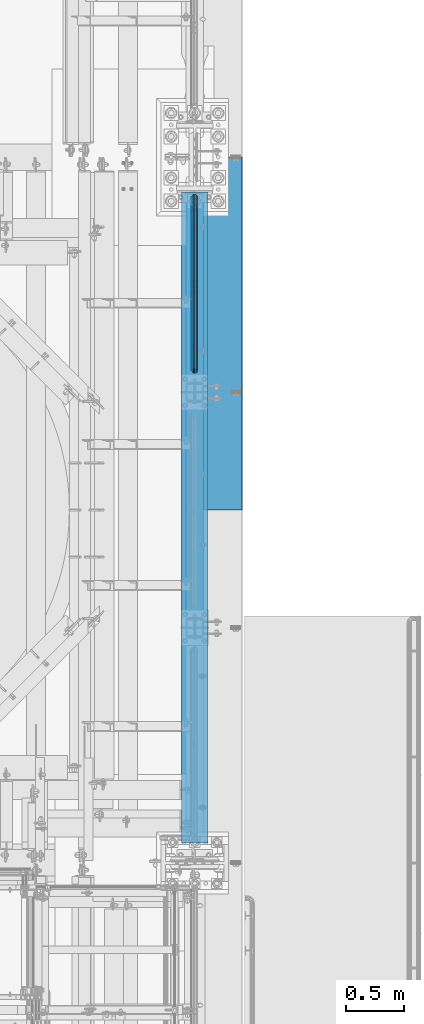
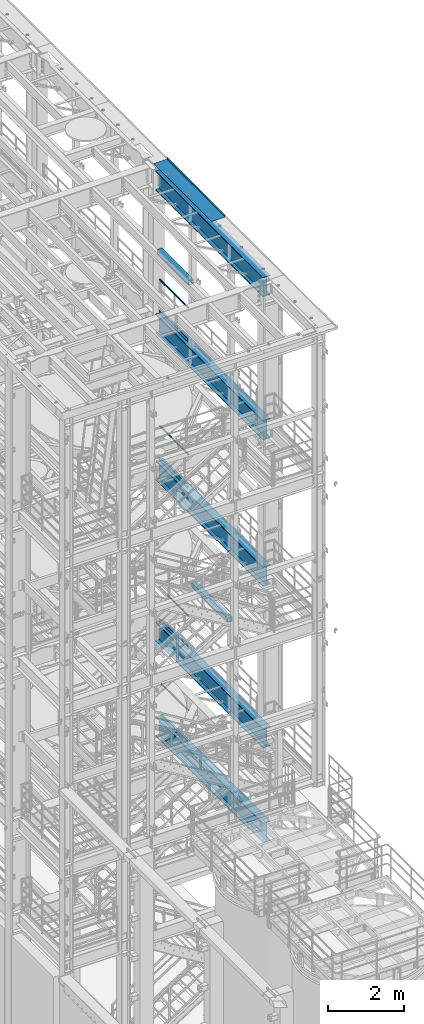
# One storey, part 1035 of 1876: 16 beams, 12 elements without a shape of their own.
"""IFC2X3 building model written with IfcOpenShell, lengths in millimetres."""

from ifc_helpers import new_model, si_unit, frame, origin_with_axes, place, context, subcontext, project, spatial, faceted_brep, material, type_object, element, aggregate, save


model = new_model("IFC2X3")

# Units and contexts
model_context = context("Model", 3, precision=1e-05, world=origin_with_axes())
body_context = subcontext(model_context, "Body", "Model", "MODEL_VIEW")
ifc_project = project(units=[si_unit("LENGTHUNIT", "METRE", prefix="MILLI"), si_unit("AREAUNIT", "SQUARE_METRE"), si_unit("VOLUMEUNIT", "CUBIC_METRE"), si_unit("MASSUNIT", "GRAM", prefix="KILO"), si_unit("TIMEUNIT", "SECOND"), si_unit("PLANEANGLEUNIT", "RADIAN"), si_unit("SOLIDANGLEUNIT", "STERADIAN"), si_unit("THERMODYNAMICTEMPERATUREUNIT", "DEGREE_CELSIUS"), si_unit("LUMINOUSINTENSITYUNIT", "LUMEN")], contexts=[model_context])

# Site, building, storey
site_placement = place(None, origin_with_axes())
site = spatial("IfcSite", under=ifc_project, at=site_placement, CompositionType="ELEMENT")
building_placement = place(site_placement, origin_with_axes())
building = spatial("IfcBuilding", under=site, at=building_placement, Name="Undefined", CompositionType="ELEMENT")
storey_placement = place(building_placement, origin_with_axes())
storey = spatial("IfcBuildingStorey", under=building, at=storey_placement, Name="Undefined", CompositionType="ELEMENT", Elevation=0.0)

# Assembly, beam
assembly_1_placement = place(storey_placement, origin_with_axes())
assembly_1 = element("IfcElementAssembly", 1, at=assembly_1_placement, inside=storey, Name="RAIL", AssemblyPlace="NOTDEFINED", PredefinedType="RIGID_FRAME")
ifc_material_1 = material()
beam_type_1 = type_object("IfcBeamType", Name="PIPE1-1/2SCH40", PredefinedType="NOTDEFINED")
beam_1_placement = place(assembly_1_placement, frame((7620.0, -342.900000000003, 19059.525), z_axis=(0.0, 0.0, -1.0), x_axis=(0.0, 1.0, 0.0)))
beam_1 = element("IfcBeam", 2, at=beam_1_placement, type_object=beam_type_1, material=ifc_material_1, Name="RAIL", ObjectType="PIPE1-1/2SCH40", context=body_context, shape_type="Brep", body=[
    faceted_brep([(24.1300000000001, -20.4469999999999, 0.0), (34.3535000000002, -17.7076214311803, 10.2235000000001), (1511.8715, -17.7076214311801, 10.2235000000001), (1522.095, -20.4470000000001, 0.0), (41.8376214311802, -10.2235000000001, 17.7076214311819), (1504.38737856882, -10.2235000000001, 17.7076214311819), (44.5770000000002, 0.0, 20.4470000000001), (1501.648, 0.0, 20.4470000000001), (41.8376214311802, 10.2235000000001, 17.7076214311819), (1504.38737856882, 10.2235000000001, 17.7076214311819), (34.3535000000002, 17.7076214311803, 10.2235000000001), (1511.8715, 17.7076214311801, 10.2235000000001), (24.1300000000001, 20.4469999999999, 0.0), (1522.095, 20.4470000000001, 0.0), (13.9065000000001, 17.7076214311803, -10.2235000000001), (1532.3185, 17.7076214311801, -10.2235000000001), (6.42237856882002, 10.2235000000001, -17.7076214311819), (1539.80262143118, 10.2235000000001, -17.7076214311819), (3.68299999999999, 0.0, -20.4470000000001), (1542.542, 0.0, -20.4470000000001), (6.42237856882002, -10.2235000000001, -17.7076214311819), (1539.80262143118, -10.2235000000001, -17.7076214311819), (13.9065000000001, -17.7076214311803, -10.2235000000001), (1532.3185, -17.7076214311801, -10.2235000000001), (24.1299999999854, -24.1299999999992, 0.0), (12.0650000000064, -20.8971929933177, -12.0649999999987), (1534.16, -20.8971929933186, -12.0649999999987), (1522.095, -24.1300000000001, 0.0), (3.23280700668147, -12.0650000000001, -20.8971929933177), (1542.99219299332, -12.0649999999996, -20.8971929933177), (-1.45519152283669e-11, 0.0, -24.130000000001), (1546.225, 0.0, -24.130000000001), (3.23280700668147, 12.0650000000001, -20.8971929933177), (1542.99219299332, 12.0649999999996, -20.8971929933177), (12.0650000000064, 20.8971929933177, -12.0649999999987), (1534.16, 20.8971929933186, -12.0649999999987), (24.1300000000047, 24.1299999999992, 0.0), (1522.095, 24.1300000000001, 0.0), (36.1949999999997, 20.8971929933184, 12.0649999999987), (1510.03, 20.8971929933186, 12.0649999999987), (45.0271929933187, 12.0650000000001, 20.8971929933177), (1501.19780700668, 12.0649999999996, 20.8971929933177), (48.2600000000002, 0.0, 24.130000000001), (1497.965, 0.0, 24.130000000001), (45.0271929933187, -12.0650000000001, 20.8971929933177), (1501.19780700668, -12.0649999999996, 20.8971929933177), (36.1949999999997, -20.8971929933184, 12.0649999999987), (1510.03, -20.8971929933186, 12.0649999999987)], [[[0, 1, 2, 3]], [[1, 4, 5, 2]], [[4, 6, 7, 5]], [[6, 8, 9, 7]], [[8, 10, 11, 9]], [[10, 12, 13, 11]], [[12, 14, 15, 13]], [[14, 16, 17, 15]], [[16, 18, 19, 17]], [[18, 20, 21, 19]], [[20, 22, 23, 21]], [[22, 0, 3, 23]], [[24, 25, 26, 27]], [[25, 28, 29, 26]], [[28, 30, 31, 29]], [[30, 32, 33, 31]], [[32, 34, 35, 33]], [[34, 36, 37, 35]], [[36, 38, 39, 37]], [[38, 40, 41, 39]], [[40, 42, 43, 41]], [[42, 44, 45, 43]], [[44, 46, 47, 45]], [[46, 24, 27, 47]], [[29, 31, 33, 35, 37, 39, 41, 43, 45, 47, 27, 26], [5, 7, 9, 11, 13, 15, 17, 19, 21, 23, 3, 2]], [[46, 44, 42, 40, 38, 36, 34, 32, 30, 28, 25, 24], [22, 20, 18, 16, 14, 12, 10, 8, 6, 4, 1, 0]]]),
])

assembly_2_placement = place(storey_placement, origin_with_axes())
assembly_2 = element("IfcElementAssembly", 3, at=assembly_2_placement, inside=storey, Name="RAIL", AssemblyPlace="NOTDEFINED", PredefinedType="RIGID_FRAME")
beam_2_placement = place(assembly_2_placement, frame((7620.0, -342.900000000005, 14385.925), z_axis=(0.0, 0.0, -1.0), x_axis=(0.0, 1.0, 0.0)))
beam_2 = element("IfcBeam", 4, at=beam_2_placement, type_object=beam_type_1, material=ifc_material_1, Name="RAIL", ObjectType="PIPE1-1/2SCH40", context=body_context, shape_type="Brep", body=[
    faceted_brep([(24.1300000000001, -20.4469999999999, 0.0), (34.3535000000002, -17.7076214311803, 10.2235000000001), (1511.8715, -17.7076214311801, 10.2235000000001), (1522.095, -20.4470000000001, 0.0), (41.8376214311802, -10.2235000000001, 17.7076214311819), (1504.38737856882, -10.2235000000001, 17.7076214311819), (44.5770000000002, 0.0, 20.4470000000001), (1501.648, 0.0, 20.4470000000001), (41.8376214311802, 10.2235000000001, 17.7076214311819), (1504.38737856882, 10.2235000000001, 17.7076214311819), (34.3535000000002, 17.7076214311803, 10.2235000000001), (1511.8715, 17.7076214311801, 10.2235000000001), (24.1300000000001, 20.4469999999999, 0.0), (1522.095, 20.4470000000001, 0.0), (13.9065000000001, 17.7076214311803, -10.2235000000001), (1532.3185, 17.7076214311801, -10.2235000000001), (6.42237856882002, 10.2235000000001, -17.7076214311819), (1539.80262143118, 10.2235000000001, -17.7076214311819), (3.68299999999999, 0.0, -20.4470000000001), (1542.542, 0.0, -20.4470000000001), (6.42237856882002, -10.2235000000001, -17.7076214311819), (1539.80262143118, -10.2235000000001, -17.7076214311819), (13.9065000000001, -17.7076214311803, -10.2235000000001), (1532.3185, -17.7076214311801, -10.2235000000001), (24.1299999999854, -24.1299999999992, 0.0), (12.0650000000064, -20.8971929933177, -12.0649999999987), (1534.16, -20.8971929933186, -12.0649999999987), (1522.095, -24.1300000000001, 0.0), (3.23280700668147, -12.0650000000001, -20.8971929933177), (1542.99219299332, -12.0649999999996, -20.8971929933177), (-1.45519152283669e-11, 0.0, -24.130000000001), (1546.225, 0.0, -24.130000000001), (3.23280700668147, 12.0650000000001, -20.8971929933177), (1542.99219299332, 12.0649999999996, -20.8971929933177), (12.0650000000064, 20.8971929933177, -12.0649999999987), (1534.16, 20.8971929933186, -12.0649999999987), (24.1300000000047, 24.1299999999992, 0.0), (1522.095, 24.1300000000001, 0.0), (36.1949999999997, 20.8971929933184, 12.0649999999987), (1510.03, 20.8971929933186, 12.0649999999987), (45.0271929933187, 12.0650000000001, 20.8971929933177), (1501.19780700668, 12.0649999999996, 20.8971929933177), (48.2600000000002, 0.0, 24.130000000001), (1497.965, 0.0, 24.130000000001), (45.0271929933187, -12.0650000000001, 20.8971929933177), (1501.19780700668, -12.0649999999996, 20.8971929933177), (36.1949999999997, -20.8971929933184, 12.0649999999987), (1510.03, -20.8971929933186, 12.0649999999987)], [[[0, 1, 2, 3]], [[1, 4, 5, 2]], [[4, 6, 7, 5]], [[6, 8, 9, 7]], [[8, 10, 11, 9]], [[10, 12, 13, 11]], [[12, 14, 15, 13]], [[14, 16, 17, 15]], [[16, 18, 19, 17]], [[18, 20, 21, 19]], [[20, 22, 23, 21]], [[22, 0, 3, 23]], [[24, 25, 26, 27]], [[25, 28, 29, 26]], [[28, 30, 31, 29]], [[30, 32, 33, 31]], [[32, 34, 35, 33]], [[34, 36, 37, 35]], [[36, 38, 39, 37]], [[38, 40, 41, 39]], [[40, 42, 43, 41]], [[42, 44, 45, 43]], [[44, 46, 47, 45]], [[46, 24, 27, 47]], [[29, 31, 33, 35, 37, 39, 41, 43, 45, 47, 27, 26], [5, 7, 9, 11, 13, 15, 17, 19, 21, 23, 3, 2]], [[46, 44, 42, 40, 38, 36, 34, 32, 30, 28, 25, 24], [22, 20, 18, 16, 14, 12, 10, 8, 6, 4, 1, 0]]]),
])

assembly_3_placement = place(storey_placement, origin_with_axes())
assembly_3 = element("IfcElementAssembly", 5, at=assembly_3_placement, inside=storey, Name="RAIL", AssemblyPlace="NOTDEFINED", PredefinedType="RIGID_FRAME")
beam_3_placement = place(assembly_3_placement, frame((7620.0, -342.900000000001, 9229.725), z_axis=(0.0, 0.0, -1.0), x_axis=(0.0, 1.0, 0.0)))
beam_3 = element("IfcBeam", 6, at=beam_3_placement, type_object=beam_type_1, material=ifc_material_1, Name="RAIL", ObjectType="PIPE1-1/2SCH40", context=body_context, shape_type="Brep", body=[
    faceted_brep([(24.1300000000001, -20.4469999999999, 0.0), (34.3535000000002, -17.7076214311803, 10.2235000000001), (1511.8715, -17.7076214311801, 10.2235000000001), (1522.095, -20.4470000000001, 0.0), (41.8376214311802, -10.2235000000001, 17.7076214311819), (1504.38737856882, -10.2235000000001, 17.7076214311819), (44.5770000000002, 0.0, 20.4470000000001), (1501.648, 0.0, 20.4470000000001), (41.8376214311802, 10.2235000000001, 17.7076214311819), (1504.38737856882, 10.2235000000001, 17.7076214311819), (34.3535000000002, 17.7076214311803, 10.2235000000001), (1511.8715, 17.7076214311801, 10.2235000000001), (24.1300000000001, 20.4469999999999, 0.0), (1522.095, 20.4470000000001, 0.0), (13.9065000000001, 17.7076214311803, -10.2235000000001), (1532.3185, 17.7076214311801, -10.2235000000001), (6.42237856882002, 10.2235000000001, -17.7076214311819), (1539.80262143118, 10.2235000000001, -17.7076214311819), (3.68299999999999, 0.0, -20.4470000000001), (1542.542, 0.0, -20.4470000000001), (6.42237856882002, -10.2235000000001, -17.7076214311819), (1539.80262143118, -10.2235000000001, -17.7076214311819), (13.9065000000001, -17.7076214311803, -10.2235000000001), (1532.3185, -17.7076214311801, -10.2235000000001), (24.1299999999854, -24.1299999999992, 0.0), (12.0650000000064, -20.8971929933177, -12.0649999999987), (1534.16, -20.8971929933186, -12.0649999999987), (1522.095, -24.1300000000001, 0.0), (3.23280700668147, -12.0650000000001, -20.8971929933177), (1542.99219299332, -12.0649999999996, -20.8971929933177), (-1.45519152283669e-11, 0.0, -24.130000000001), (1546.225, 0.0, -24.130000000001), (3.23280700668147, 12.0650000000001, -20.8971929933177), (1542.99219299332, 12.0649999999996, -20.8971929933177), (12.0650000000064, 20.8971929933177, -12.0649999999987), (1534.16, 20.8971929933186, -12.0649999999987), (24.1300000000047, 24.1299999999992, 0.0), (1522.095, 24.1300000000001, 0.0), (36.1949999999997, 20.8971929933184, 12.0649999999987), (1510.03, 20.8971929933186, 12.0649999999987), (45.0271929933187, 12.0650000000001, 20.8971929933177), (1501.19780700668, 12.0649999999996, 20.8971929933177), (48.2600000000002, 0.0, 24.130000000001), (1497.965, 0.0, 24.130000000001), (45.0271929933187, -12.0650000000001, 20.8971929933177), (1501.19780700668, -12.0649999999996, 20.8971929933177), (36.1949999999997, -20.8971929933184, 12.0649999999987), (1510.03, -20.8971929933186, 12.0649999999987)], [[[0, 1, 2, 3]], [[1, 4, 5, 2]], [[4, 6, 7, 5]], [[6, 8, 9, 7]], [[8, 10, 11, 9]], [[10, 12, 13, 11]], [[12, 14, 15, 13]], [[14, 16, 17, 15]], [[16, 18, 19, 17]], [[18, 20, 21, 19]], [[20, 22, 23, 21]], [[22, 0, 3, 23]], [[24, 25, 26, 27]], [[25, 28, 29, 26]], [[28, 30, 31, 29]], [[30, 32, 33, 31]], [[32, 34, 35, 33]], [[34, 36, 37, 35]], [[36, 38, 39, 37]], [[38, 40, 41, 39]], [[40, 42, 43, 41]], [[42, 44, 45, 43]], [[44, 46, 47, 45]], [[46, 24, 27, 47]], [[29, 31, 33, 35, 37, 39, 41, 43, 45, 47, 27, 26], [5, 7, 9, 11, 13, 15, 17, 19, 21, 23, 3, 2]], [[46, 44, 42, 40, 38, 36, 34, 32, 30, 28, 25, 24], [22, 20, 18, 16, 14, 12, 10, 8, 6, 4, 1, 0]]]),
])

assembly_4_placement = place(storey_placement, origin_with_axes())
assembly_4 = element("IfcElementAssembly", 7, at=assembly_4_placement, inside=storey, Name="RAIL", AssemblyPlace="NOTDEFINED", PredefinedType="RIGID_FRAME")
beam_4_placement = place(assembly_4_placement, frame((7620.00000000068, 1108.0396633614, 6207.13724280096), z_axis=(0.0, 7.91400000045761e-06, -0.999999999968684), x_axis=(0.0, -0.999999999968684, -7.91400000071008e-06)))
beam_4 = element("IfcBeam", 8, at=beam_4_placement, type_object=beam_type_1, material=ifc_material_1, Name="RAIL", ObjectType="PIPE1-1/2SCH40", context=body_context, shape_type="Brep", body=[
    faceted_brep([(24.1297889306325, -20.4470000000001, 4.54747350886464e-12), (34.3533782626628, -17.7076214311801, 10.223500000001), (1416.58624781054, -17.7076214311801, 10.2235000002374), (1426.80965847928, -20.4470000000001, 2.42835085373372e-10), (41.8375650894295, -10.2235000000001, 17.7076214311801), (1409.10219177439, -10.2235000000001, 17.7076214314138), (44.5770000000002, 0.0, 20.4470000000001), (1406.3628371418, 0.0, 20.4470000002311), (41.8375650894295, 10.2235000000001, 17.7076214311801), (1409.10219177439, 10.2235000000001, 17.7076214314138), (34.3533782626628, 17.7076214311801, 10.223500000001), (1416.58624781054, 17.7076214311801, 10.2235000002374), (24.1297889306325, 20.4470000000001, 4.54747350886464e-12), (1426.80965847928, 20.4470000000001, 2.42835085373372e-10), (13.9061995986012, 17.7076214311801, -10.2234999999919), (1437.03306914802, 17.7076214311801, -10.2234999997499), (6.42201277183449, 10.2235000000001, -17.707621431171), (1444.51712518418, 10.2235000000001, -17.7076214309263), (3.68261026657001, 0.0, -20.4469999999901), (1447.25647981676, 0.0, -20.4469999997445), (6.42201277183449, -10.2235000000001, -17.707621431171), (1444.51712518418, -10.2235000000001, -17.7076214309263), (13.9061995986012, -17.7076214311801, -10.2234999999919), (1437.03306914802, -17.7076214311801, -10.2234999997499), (24.1297889306325, -24.1300000000001, 4.54747350886464e-12), (12.0646835077378, -20.8971929933186, -12.0649999999923), (1438.8745530573, -20.8971929933186, -12.0649999997486), (1426.80965847928, -24.1300000000001, 2.42835085373372e-10), (3.23241333950409, -12.0649999999996, -20.8971929933086), (1447.70666887637, -12.0649999999996, -20.8971929930613), (-0.000421915156039177, 0.0, -24.1299999999892), (1450.93944763532, 0.0, -24.1299999997409), (3.23241333950409, 12.0649999999996, -20.8971929933086), (1447.70666887637, 12.0649999999996, -20.8971929930613), (12.0646835077378, 20.8971929933186, -12.0649999999923), (1438.8745530573, 20.8971929933186, -12.0649999997486), (24.1297889306325, 24.1300000000001, 4.54747350886464e-12), (1426.80965847928, 24.1300000000001, 2.42835085373372e-10), (36.1948943535272, 20.8971929933186, 12.0650000000014), (1414.74476390127, 20.8971929933186, 12.0650000002352), (45.0271929933187, 12.0650000000001, 20.8971929933177), (1405.9126480822, 12.0649999999996, 20.8971929935497), (48.2600000000002, 0.0, 24.130000000001), (1402.67986932325, 0.0, 24.1300000002293), (45.0271929933187, -12.0650000000001, 20.8971929933177), (1405.9126480822, -12.0649999999996, 20.8971929935497), (36.1948943535263, -20.8971929933186, 12.0650000000014), (1414.74476390127, -20.8971929933186, 12.0650000002352)], [[[0, 1, 2, 3]], [[1, 4, 5, 2]], [[4, 6, 7, 5]], [[6, 8, 9, 7]], [[8, 10, 11, 9]], [[10, 12, 13, 11]], [[12, 14, 15, 13]], [[14, 16, 17, 15]], [[16, 18, 19, 17]], [[18, 20, 21, 19]], [[20, 22, 23, 21]], [[22, 0, 3, 23]], [[24, 25, 26, 27]], [[25, 28, 29, 26]], [[28, 30, 31, 29]], [[30, 32, 33, 31]], [[32, 34, 35, 33]], [[34, 36, 37, 35]], [[36, 38, 39, 37]], [[38, 40, 41, 39]], [[40, 42, 43, 41]], [[42, 44, 45, 43]], [[44, 46, 47, 45]], [[46, 24, 27, 47]], [[29, 31, 33, 35, 37, 39, 41, 43, 45, 47, 27, 26], [5, 7, 9, 11, 13, 15, 17, 19, 21, 23, 3, 2]], [[46, 44, 42, 40, 38, 36, 34, 32, 30, 28, 25, 24], [22, 20, 18, 16, 14, 12, 10, 8, 6, 4, 1, 0]]]),
])

assembly_5_placement = place(storey_placement, origin_with_axes())
assembly_5 = element("IfcElementAssembly", 9, at=assembly_5_placement, inside=storey, Name="BEAM", AssemblyPlace="NOTDEFINED", PredefinedType="RIGID_FRAME")
ifc_material_2 = material()
beam_type_2 = type_object("IfcBeamType", Name="HSS6X6X3/8", PredefinedType="NOTDEFINED")
beam_5_placement = place(assembly_5_placement, frame((7620.0, -508.0, 19958.05), z_axis=(-1.0, 0.0, 0.0), x_axis=(0.0, 1.0, 0.0)))
beam_5 = element("IfcBeam", 10, at=beam_5_placement, type_object=beam_type_2, material=ifc_material_2, Name="BEAM", ObjectType="HSS6X6X3/8", context=body_context, shape_type="Brep", body=[
    faceted_brep([(76.2000000000007, 66.6749999999993, -66.6750000000002), (76.2000000000007, -66.6749999999993, -66.6750000000002), (1720.85, -66.6749999999993, -66.675), (1720.85, 66.6749999999993, -66.675), (76.2000000000007, -66.6749999999993, 66.6750000000002), (1720.85, -66.6749999999993, 66.675), (76.2000000000007, 66.6749999999993, 66.6750000000002), (1720.85, 66.6749999999993, 66.675), (76.2000000000007, 76.2000000000007, -76.1999999999998), (76.2000000000007, 76.2000000000007, 76.1999999999998), (1720.85, 76.2000000000007, 76.2), (1720.85, 76.2000000000007, -76.2), (76.2000000000007, -76.2000000000007, 76.1999999999998), (1720.85, -76.2000000000007, 76.2), (76.2000000000007, -76.2000000000007, -76.1999999999998), (1720.85, -76.2000000000007, -76.2)], [[[0, 1, 2, 3]], [[1, 4, 5, 2]], [[4, 6, 7, 5]], [[6, 0, 3, 7]], [[8, 9, 10, 11]], [[9, 12, 13, 10]], [[12, 14, 15, 13]], [[14, 8, 11, 15]], [[13, 15, 11, 10], [5, 7, 3, 2]], [[14, 12, 9, 8], [6, 4, 1, 0]]]),
])
aggregate(assembly_5, [beam_5])

assembly_6_placement = place(storey_placement, origin_with_axes())
assembly_6 = element("IfcElementAssembly", 11, at=assembly_6_placement, inside=storey, Name="BEAM", AssemblyPlace="NOTDEFINED", PredefinedType="RIGID_FRAME")
beam_6_placement = place(assembly_6_placement, frame((7620.0, -2540.0, 10420.35), z_axis=(-1.0, 0.0, 0.0), x_axis=(0.0, 1.0, 0.0)))
beam_6 = element("IfcBeam", 12, at=beam_6_placement, type_object=beam_type_2, material=ifc_material_2, Name="BEAM", ObjectType="HSS6X6X3/8", context=body_context, shape_type="Brep", body=[
    faceted_brep([(76.2000000000007, 66.6749999999993, -66.6750000000002), (76.2000000000007, -66.6749999999993, -66.6750000000002), (1955.8, -66.6749999999993, -66.675), (1955.8, 66.6749999999993, -66.675), (76.2000000000007, -66.6749999999993, 66.6750000000002), (1955.8, -66.6749999999993, 66.675), (76.2000000000007, 66.6749999999993, 66.6750000000002), (1955.8, 66.6749999999993, 66.675), (76.2000000000007, 76.2000000000007, -76.1999999999998), (76.2000000000007, 76.2000000000007, 76.1999999999998), (1955.8, 76.2000000000007, 76.2), (1955.8, 76.2000000000007, -76.2), (76.2000000000007, -76.2000000000007, 76.1999999999998), (1955.8, -76.2000000000007, 76.2), (76.2000000000007, -76.2000000000007, -76.1999999999998), (1955.8, -76.2000000000007, -76.2)], [[[0, 1, 2, 3]], [[1, 4, 5, 2]], [[4, 6, 7, 5]], [[6, 0, 3, 7]], [[8, 9, 10, 11]], [[9, 12, 13, 10]], [[12, 14, 15, 13]], [[14, 8, 11, 15]], [[13, 15, 11, 10], [5, 7, 3, 2]], [[14, 12, 9, 8], [6, 4, 1, 0]]]),
])
aggregate(assembly_6, [beam_6])

# Beam
ifc_material_3 = material(Name="STEEL/A36")
beam_type_3 = type_object("IfcBeamType", PredefinedType="NOTDEFINED")
beam_7_placement = place(assembly_1_placement, frame((7592.69500000001, -318.77, 18049.8809122948), z_axis=(0.0, 0.0, 1.0), x_axis=(0.0, 1.0, 0.0)))
beam_7 = element("IfcBeam", 13, at=beam_7_placement, type_object=beam_type_3, material=ifc_material_3, Name="PLATE", context=body_context, shape_type="Brep", body=[
    faceted_brep([(0.0, 3.17500000000018, -50.8000000000002), (0.0, 3.17500000000018, 50.8000000000002), (1497.965, 3.175, 50.7999999999993), (1497.965, 3.175, -50.7999999999993), (0.0, -3.17500000000018, 50.8000000000002), (1497.965, -3.175, 50.7999999999993), (0.0, -3.17500000000018, -50.8000000000002), (1497.965, -3.175, -50.7999999999993)], [[[0, 1, 2, 3]], [[1, 4, 5, 2]], [[4, 6, 7, 5]], [[6, 0, 3, 7]], [[5, 7, 3, 2]], [[6, 4, 1, 0]]]),
])

aggregate(assembly_1, [beam_7, beam_1])

beam_8_placement = place(assembly_2_placement, frame((7592.69500000001, -318.770000000002, 13376.2809122948), z_axis=(0.0, 0.0, 1.0), x_axis=(0.0, 1.0, 0.0)))
beam_8 = element("IfcBeam", 14, at=beam_8_placement, type_object=beam_type_3, material=ifc_material_3, Name="PLATE", context=body_context, shape_type="Brep", body=[
    faceted_brep([(0.0, 3.17500000000018, -50.8000000000002), (0.0, 3.17500000000018, 50.8000000000002), (1497.965, 3.175, 50.7999999999993), (1497.965, 3.175, -50.7999999999993), (0.0, -3.17500000000018, 50.8000000000002), (1497.965, -3.175, 50.7999999999993), (0.0, -3.17500000000018, -50.8000000000002), (1497.965, -3.175, -50.7999999999993)], [[[0, 1, 2, 3]], [[1, 4, 5, 2]], [[4, 6, 7, 5]], [[6, 0, 3, 7]], [[5, 7, 3, 2]], [[6, 4, 1, 0]]]),
])

aggregate(assembly_2, [beam_8, beam_2])

beam_9_placement = place(assembly_3_placement, frame((7592.69500000001, -318.769999999999, 8220.08091229478), z_axis=(0.0, 0.0, 1.0), x_axis=(0.0, 1.0, 0.0)))
beam_9 = element("IfcBeam", 15, at=beam_9_placement, type_object=beam_type_3, material=ifc_material_3, Name="PLATE", context=body_context, shape_type="Brep", body=[
    faceted_brep([(0.0, 3.17500000000018, -50.8000000000002), (0.0, 3.17500000000018, 50.8000000000002), (1497.965, 3.175, 50.7999999999993), (1497.965, 3.175, -50.7999999999993), (0.0, -3.17500000000018, 50.8000000000002), (1497.965, -3.175, 50.7999999999993), (0.0, -3.17500000000018, -50.8000000000002), (1497.965, -3.175, -50.7999999999993)], [[[0, 1, 2, 3]], [[1, 4, 5, 2]], [[4, 6, 7, 5]], [[6, 0, 3, 7]], [[5, 7, 3, 2]], [[6, 4, 1, 0]]]),
])

aggregate(assembly_3, [beam_9, beam_3])

beam_10_placement = place(assembly_4_placement, frame((7592.69500000001, -318.770000000004, 5197.48091229478), z_axis=(0.0, 0.0, 1.0), x_axis=(0.0, 1.0, 0.0)))
beam_10 = element("IfcBeam", 16, at=beam_10_placement, type_object=beam_type_3, material=ifc_material_3, Name="PLATE", context=body_context, shape_type="Brep", body=[
    faceted_brep([(0.0, 3.17500000000018, -50.8000000000002), (0.0, 3.17500000000018, 50.8000000000002), (1402.6796633614, 3.175, 50.8000000000002), (1402.6796633614, 3.175, -50.8000000000002), (0.0, -3.17500000000018, 50.8000000000002), (1402.6796633614, -3.175, 50.8000000000002), (0.0, -3.17500000000018, -50.8000000000002), (1402.6796633614, -3.175, -50.8000000000002)], [[[0, 1, 2, 3]], [[1, 4, 5, 2]], [[4, 6, 7, 5]], [[6, 0, 3, 7]], [[5, 7, 3, 2]], [[6, 4, 1, 0]]]),
])

aggregate(assembly_4, [beam_10, beam_4])

# Assembly, beam
assembly_7_placement = place(storey_placement, origin_with_axes())
assembly_7 = element("IfcElementAssembly", 17, at=assembly_7_placement, inside=storey, Name="BENT PLATE", AssemblyPlace="NOTDEFINED", PredefinedType="RIGID_FRAME")
beam_type_4 = type_object("IfcBeamType", PredefinedType="NOTDEFINED")
beam_11_placement = place(assembly_7_placement, frame((7619.99998321378, 0.0, 22558.375), z_axis=(0.0, 1.0, 0.0), x_axis=(0.999999999986024, 0.0, -5.28699999861059e-06)))
beam_11 = element("IfcBeam", 18, at=beam_11_placement, type_object=beam_type_4, material=ifc_material_3, Name="BENT PLATE", context=body_context, shape_type="Brep", body=[
    faceted_brep([(9.877112461254e-10, -3.17499999999563, -1524.0), (9.877112461254e-10, -3.17499999999563, 1524.0), (-9.88620740827173e-10, 3.17500000000291, 1524.0), (-9.88620740827173e-10, 3.17500000000291, -1524.0), (412.74996162189, 3.17499999736538, 1524.0), (412.74996162189, 3.17499999736538, -1524.0), (406.399963385245, -3.17500000258951, -1524.0), (406.399963385245, -3.17500000258951, 1524.0), (412.749980137296, -63.5005721684938, 1524.0), (412.749980137296, -63.5005721684938, -1524.0), (406.399980137296, -63.5005739318367, 1524.0), (406.399980137296, -63.5005739318367, -1524.0)], [[[0, 1, 2, 3]], [[3, 2, 4, 5]], [[1, 0, 6, 7]], [[5, 4, 8, 9]], [[4, 2, 1, 7, 10, 8]], [[7, 6, 11, 10]], [[6, 0, 3, 5, 9, 11]], [[10, 11, 9, 8]]]),
])
aggregate(assembly_7, [beam_11])

assembly_8_placement = place(storey_placement, origin_with_axes())
assembly_8 = element("IfcElementAssembly", 19, at=assembly_8_placement, inside=storey, Name="BEAM", AssemblyPlace="NOTDEFINED", PredefinedType="RIGID_FRAME")
ifc_material_4 = material(Name="STEEL/A992")
beam_type_5 = type_object("IfcBeamType", Name="W24X103", PredefinedType="NOTDEFINED")
beam_12_placement = place(assembly_8_placement, frame((7620.0, -4572.0, 17672.05), z_axis=(0.0, 0.0, 1.0), x_axis=(0.0, 1.0, 0.0)))
beam_12 = element("IfcBeam", 20, at=beam_12_placement, type_object=beam_type_5, material=ifc_material_4, Name="BEAM", ObjectType="W24X103", context=body_context, shape_type="Brep", body=[
    faceted_brep([(173.037499999999, -114.3, -285.75), (173.037499999999, -114.3, -311.150000000001), (5794.375, -114.3, -311.150000000001), (5794.375, -114.3, -285.75), (173.037499999999, -7.14375000000018, -285.75), (5794.375, -7.14375000000018, -285.75), (173.037499999999, -7.14375000000018, 285.75), (5794.375, -7.14375000000018, 285.75), (173.037499999999, -114.3, 285.75), (5794.375, -114.3, 285.75), (173.037499999999, -114.3, 311.150000000001), (5794.375, -114.3, 311.150000000001), (173.037499999999, 114.3, 311.150000000001), (5794.375, 114.3, 311.150000000001), (173.037499999999, 114.3, 285.75), (5794.375, 114.3, 285.75), (173.037499999999, 7.14375000000018, 285.75), (5794.375, 7.14375000000018, 285.75), (173.037499999999, 7.14375000000018, -285.75), (5794.375, 7.14375000000018, -285.75), (173.037499999999, 114.3, -285.75), (5794.375, 114.3, -285.75), (173.037499999999, 114.3, -311.150000000001), (5794.375, 114.3, -311.150000000001)], [[[0, 1, 2, 3]], [[4, 0, 3, 5]], [[6, 4, 5, 7]], [[8, 6, 7, 9]], [[10, 8, 9, 11]], [[12, 10, 11, 13]], [[14, 12, 13, 15]], [[16, 14, 15, 17]], [[18, 16, 17, 19]], [[20, 18, 19, 21]], [[1, 0, 4, 6, 8, 10, 12, 14, 16, 18, 20, 22]], [[1, 22, 23, 2]], [[19, 17, 15, 13, 11, 9, 7, 5, 3, 2, 23, 21]], [[22, 20, 21, 23]]]),
])
aggregate(assembly_8, [beam_12])

assembly_9_placement = place(storey_placement, origin_with_axes())
assembly_9 = element("IfcElementAssembly", 21, at=assembly_9_placement, inside=storey, Name="BEAM", AssemblyPlace="NOTDEFINED", PredefinedType="RIGID_FRAME")
beam_13_placement = place(assembly_9_placement, frame((7620.0, -4572.0, 12998.45), z_axis=(0.0, 0.0, 1.0), x_axis=(0.0, 1.0, 0.0)))
beam_13 = element("IfcBeam", 22, at=beam_13_placement, type_object=beam_type_5, material=ifc_material_4, Name="BEAM", ObjectType="W24X103", context=body_context, shape_type="Brep", body=[
    faceted_brep([(173.037499999999, -114.3, -285.75), (173.037499999999, -114.3, -311.150000000001), (5794.375, -114.3, -311.150000000001), (5794.375, -114.3, -285.75), (173.037499999999, -7.14375000000018, -285.75), (5794.375, -7.14375000000018, -285.75), (173.037499999999, -7.14375000000018, 285.75), (5794.375, -7.14375000000018, 285.75), (173.037499999999, -114.3, 285.75), (5794.375, -114.3, 285.75), (173.037499999999, -114.3, 311.150000000001), (5794.375, -114.3, 311.150000000001), (173.037499999999, 114.3, 311.150000000001), (5794.375, 114.3, 311.150000000001), (173.037499999999, 114.3, 285.75), (5794.375, 114.3, 285.75), (173.037499999999, 7.14375000000018, 285.75), (5794.375, 7.14375000000018, 285.75), (173.037499999999, 7.14375000000018, -285.75), (5794.375, 7.14375000000018, -285.75), (173.037499999999, 114.3, -285.75), (5794.375, 114.3, -285.75), (173.037499999999, 114.3, -311.150000000001), (5794.375, 114.3, -311.150000000001)], [[[0, 1, 2, 3]], [[4, 0, 3, 5]], [[6, 4, 5, 7]], [[8, 6, 7, 9]], [[10, 8, 9, 11]], [[12, 10, 11, 13]], [[14, 12, 13, 15]], [[16, 14, 15, 17]], [[18, 16, 17, 19]], [[20, 18, 19, 21]], [[1, 0, 4, 6, 8, 10, 12, 14, 16, 18, 20, 22]], [[1, 22, 23, 2]], [[19, 17, 15, 13, 11, 9, 7, 5, 3, 2, 23, 21]], [[22, 20, 21, 23]]]),
])
aggregate(assembly_9, [beam_13])

assembly_10_placement = place(storey_placement, origin_with_axes())
assembly_10 = element("IfcElementAssembly", 23, at=assembly_10_placement, inside=storey, Name="BEAM", AssemblyPlace="NOTDEFINED", PredefinedType="RIGID_FRAME")
beam_14_placement = place(assembly_10_placement, frame((7620.0, -4572.0, 7842.25), z_axis=(0.0, 0.0, 1.0), x_axis=(0.0, 1.0, 0.0)))
beam_14 = element("IfcBeam", 24, at=beam_14_placement, type_object=beam_type_5, material=ifc_material_4, Name="BEAM", ObjectType="W24X103", context=body_context, shape_type="Brep", body=[
    faceted_brep([(173.037499999999, -114.3, -285.75), (173.037499999999, -114.3, -311.150000000001), (5794.375, -114.3, -311.150000000001), (5794.375, -114.3, -285.75), (173.037499999999, -7.14375000000018, -285.75), (5794.375, -7.14375000000018, -285.75), (173.037499999999, -7.14375000000018, 285.75), (5794.375, -7.14375000000018, 285.75), (173.037499999999, -114.3, 285.75), (5794.375, -114.3, 285.75), (173.037499999999, -114.3, 311.150000000001), (5794.375, -114.3, 311.150000000001), (173.037499999999, 114.3, 311.150000000001), (5794.375, 114.3, 311.150000000001), (173.037499999999, 114.3, 285.75), (5794.375, 114.3, 285.75), (173.037499999999, 7.14375000000018, 285.75), (5794.375, 7.14375000000018, 285.75), (173.037499999999, 7.14375000000018, -285.75), (5794.375, 7.14375000000018, -285.75), (173.037499999999, 114.3, -285.75), (5794.375, 114.3, -285.75), (173.037499999999, 114.3, -311.150000000001), (5794.375, 114.3, -311.150000000001)], [[[0, 1, 2, 3]], [[4, 0, 3, 5]], [[6, 4, 5, 7]], [[8, 6, 7, 9]], [[10, 8, 9, 11]], [[12, 10, 11, 13]], [[14, 12, 13, 15]], [[16, 14, 15, 17]], [[18, 16, 17, 19]], [[20, 18, 19, 21]], [[1, 0, 4, 6, 8, 10, 12, 14, 16, 18, 20, 22]], [[1, 22, 23, 2]], [[19, 17, 15, 13, 11, 9, 7, 5, 3, 2, 23, 21]], [[22, 20, 21, 23]]]),
])
aggregate(assembly_10, [beam_14])

assembly_11_placement = place(storey_placement, origin_with_axes())
assembly_11 = element("IfcElementAssembly", 25, at=assembly_11_placement, inside=storey, Name="BEAM", AssemblyPlace="NOTDEFINED", PredefinedType="RIGID_FRAME")
beam_15_placement = place(assembly_11_placement, frame((7620.0, -4572.0, 22244.05), z_axis=(0.0, 0.0, 1.0), x_axis=(0.0, 1.0, 0.0)))
beam_15 = element("IfcBeam", 26, at=beam_15_placement, type_object=beam_type_5, material=ifc_material_4, Name="BEAM", ObjectType="W24X103", context=body_context, shape_type="Brep", body=[
    faceted_brep([(173.037499999999, -114.3, -285.75), (173.037499999999, -114.3, -311.150000000001), (5794.375, -114.3, -311.150000000001), (5794.375, -114.3, -285.75), (173.037499999999, -7.14375000000018, -285.75), (5794.375, -7.14375000000018, -285.75), (173.037499999999, -7.14375000000018, 285.75), (5794.375, -7.14375000000018, 285.75), (173.037499999999, -114.3, 285.75), (5794.375, -114.3, 285.75), (173.037499999999, -114.3, 311.150000000001), (5794.375, -114.3, 311.150000000001), (173.037499999999, 114.3, 311.150000000001), (5794.375, 114.3, 311.150000000001), (173.037499999999, 114.3, 285.75), (5794.375, 114.3, 285.75), (173.037499999999, 7.14375000000018, 285.75), (5794.375, 7.14375000000018, 285.75), (173.037499999999, 7.14375000000018, -285.75), (5794.375, 7.14375000000018, -285.75), (173.037499999999, 114.3, -285.75), (5794.375, 114.3, -285.75), (173.037499999999, 114.3, -311.150000000001), (5794.375, 114.3, -311.150000000001)], [[[0, 1, 2, 3]], [[4, 0, 3, 5]], [[6, 4, 5, 7]], [[8, 6, 7, 9]], [[10, 8, 9, 11]], [[12, 10, 11, 13]], [[14, 12, 13, 15]], [[16, 14, 15, 17]], [[18, 16, 17, 19]], [[20, 18, 19, 21]], [[1, 0, 4, 6, 8, 10, 12, 14, 16, 18, 20, 22]], [[1, 22, 23, 2]], [[19, 17, 15, 13, 11, 9, 7, 5, 3, 2, 23, 21]], [[22, 20, 21, 23]]]),
])
aggregate(assembly_11, [beam_15])

assembly_12_placement = place(storey_placement, origin_with_axes())
assembly_12 = element("IfcElementAssembly", 27, at=assembly_12_placement, inside=storey, Name="BEAM", AssemblyPlace="NOTDEFINED", PredefinedType="RIGID_FRAME")
beam_16_placement = place(assembly_12_placement, frame((7620.0, -4572.0, 4819.65), z_axis=(0.0, 0.0, 1.0), x_axis=(0.0, 1.0, 0.0)))
beam_16 = element("IfcBeam", 28, at=beam_16_placement, type_object=beam_type_5, material=ifc_material_4, Name="BEAM", ObjectType="W24X103", context=body_context, shape_type="Brep", body=[
    faceted_brep([(173.037499999999, -114.3, -285.75), (173.037499999999, -114.3, -311.150000000001), (5794.375, -114.3, -311.150000000001), (5794.375, -114.3, -285.75), (173.037499999999, -7.14375000000018, -285.75), (5794.375, -7.14375000000018, -285.75), (173.037499999999, -7.14375000000018, 285.75), (5794.375, -7.14375000000018, 285.75), (173.037499999999, -114.3, 285.75), (5794.375, -114.3, 285.75), (173.037499999999, -114.3, 311.150000000001), (5794.375, -114.3, 311.150000000001), (173.037499999999, 114.3, 311.150000000001), (5794.375, 114.3, 311.150000000001), (173.037499999999, 114.3, 285.75), (5794.375, 114.3, 285.75), (173.037499999999, 7.14375000000018, 285.75), (5794.375, 7.14375000000018, 285.75), (173.037499999999, 7.14375000000018, -285.75), (5794.375, 7.14375000000018, -285.75), (173.037499999999, 114.3, -285.75), (5794.375, 114.3, -285.75), (173.037499999999, 114.3, -311.150000000001), (5794.375, 114.3, -311.150000000001)], [[[0, 1, 2, 3]], [[4, 0, 3, 5]], [[6, 4, 5, 7]], [[8, 6, 7, 9]], [[10, 8, 9, 11]], [[12, 10, 11, 13]], [[14, 12, 13, 15]], [[16, 14, 15, 17]], [[18, 16, 17, 19]], [[20, 18, 19, 21]], [[1, 0, 4, 6, 8, 10, 12, 14, 16, 18, 20, 22]], [[1, 22, 23, 2]], [[19, 17, 15, 13, 11, 9, 7, 5, 3, 2, 23, 21]], [[22, 20, 21, 23]]]),
])
aggregate(assembly_12, [beam_16])

save(model, "model.ifc")
